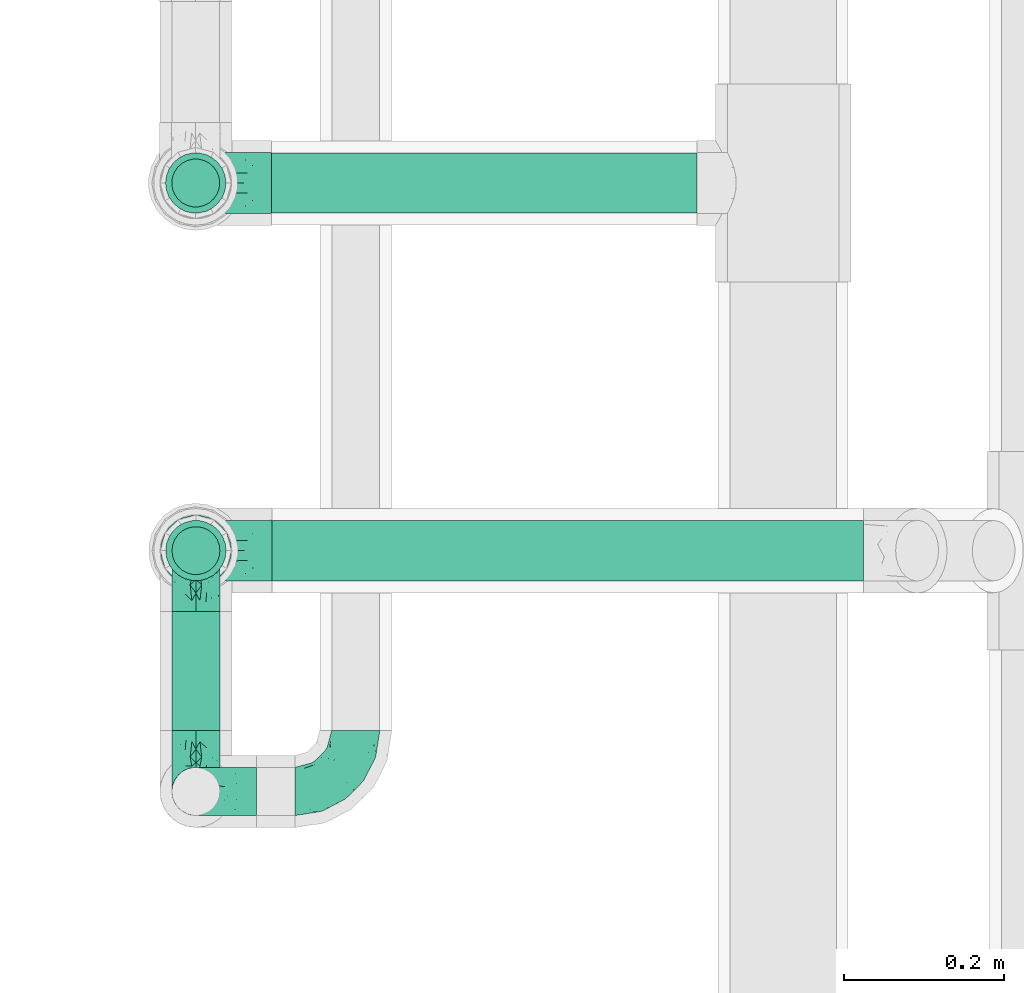
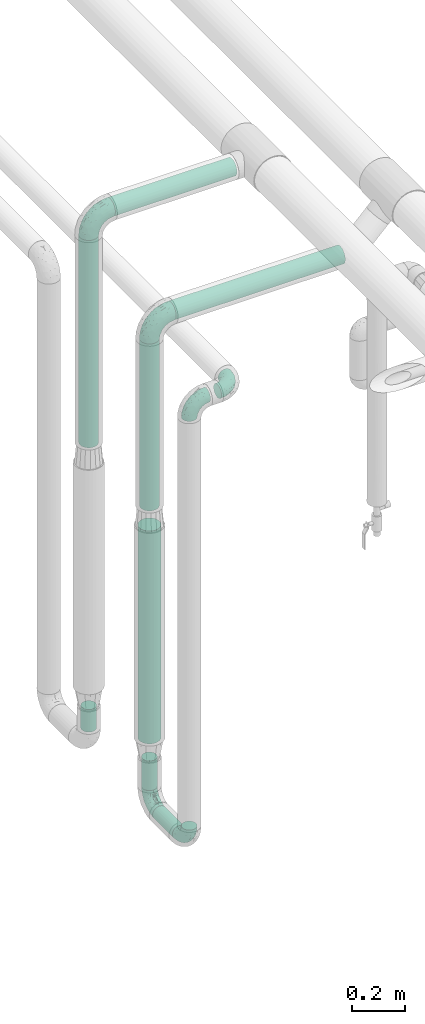
# One storey, part 553 of 824: 8 flow segments, 6 flow fittings.
"""IFC2X3 building model written with IfcOpenShell, lengths in millimetres."""

from ifc_helpers import new_model, entity, si_unit, converted_unit, derived_unit, direction, frame, origin, origin_2d_with_axis, place, context, subcontext, project, spatial, circle, extrude, faceted_brep, source, transform, mapped, material, type_object, type_shapes, element, save


model = new_model("IFC2X3")

# Units and contexts
model_context = context("Model", 3, precision=0.01, world=origin(), true_north=direction((6.12303176911189e-17, 1.0)))
body_context = subcontext(model_context, "Body", "Model", "MODEL_VIEW")
ifc_project = project(units=[si_unit("LENGTHUNIT", "METRE", prefix="MILLI"), si_unit("AREAUNIT", "SQUARE_METRE"), si_unit("VOLUMEUNIT", "CUBIC_METRE"), converted_unit("PLANEANGLEUNIT", "DEGREE", entity("IfcRatioMeasure", 0.0174532925199433), si_unit("PLANEANGLEUNIT", "RADIAN"), dimensions=[0, 0, 0, 0, 0, 0, 0]), si_unit("MASSUNIT", "GRAM", prefix="KILO"), derived_unit("MASSDENSITYUNIT", [(si_unit("MASSUNIT", "GRAM", prefix="KILO"), 1), (si_unit("LENGTHUNIT", "METRE"), -3)]), derived_unit("MOMENTOFINERTIAUNIT", [(si_unit("LENGTHUNIT", "METRE"), 4)]), si_unit("TIMEUNIT", "SECOND"), si_unit("FREQUENCYUNIT", "HERTZ"), si_unit("THERMODYNAMICTEMPERATUREUNIT", "DEGREE_CELSIUS"), derived_unit("THERMALTRANSMITTANCEUNIT", [(si_unit("MASSUNIT", "GRAM", prefix="KILO"), 1), (si_unit("THERMODYNAMICTEMPERATUREUNIT", "KELVIN"), -1), (si_unit("TIMEUNIT", "SECOND"), -3)]), derived_unit("VOLUMETRICFLOWRATEUNIT", [(si_unit("LENGTHUNIT", "METRE"), 3), (si_unit("TIMEUNIT", "SECOND"), -1)]), derived_unit("MASSFLOWRATEUNIT", [(si_unit("MASSUNIT", "GRAM", prefix="KILO"), 1), (si_unit("TIMEUNIT", "SECOND"), -1)]), derived_unit("ROTATIONALFREQUENCYUNIT", [(si_unit("TIMEUNIT", "SECOND"), -1)]), si_unit("ELECTRICCURRENTUNIT", "AMPERE"), si_unit("ELECTRICVOLTAGEUNIT", "VOLT"), si_unit("POWERUNIT", "WATT"), si_unit("FORCEUNIT", "NEWTON", prefix="KILO"), si_unit("ILLUMINANCEUNIT", "LUX"), si_unit("LUMINOUSFLUXUNIT", "LUMEN"), si_unit("LUMINOUSINTENSITYUNIT", "CANDELA"), derived_unit("USERDEFINED", [(si_unit("MASSUNIT", "GRAM", prefix="KILO"), -1), (si_unit("LENGTHUNIT", "METRE"), -2), (si_unit("TIMEUNIT", "SECOND"), 3), (si_unit("LUMINOUSFLUXUNIT", "LUMEN"), 1)]), derived_unit("LINEARVELOCITYUNIT", [(si_unit("LENGTHUNIT", "METRE"), 1), (si_unit("TIMEUNIT", "SECOND"), -1)]), si_unit("PRESSUREUNIT", "PASCAL"), derived_unit("USERDEFINED", [(si_unit("LENGTHUNIT", "METRE"), -2), (si_unit("MASSUNIT", "GRAM", prefix="KILO"), 1), (si_unit("TIMEUNIT", "SECOND"), -2)]), derived_unit("LINEARFORCEUNIT", [(si_unit("MASSUNIT", "GRAM", prefix="KILO"), 1), (si_unit("LENGTHUNIT", "METRE"), 1), (si_unit("TIMEUNIT", "SECOND"), -2), (si_unit("LENGTHUNIT", "METRE"), -1)]), derived_unit("PLANARFORCEUNIT", [(si_unit("MASSUNIT", "GRAM", prefix="KILO"), 1), (si_unit("LENGTHUNIT", "METRE"), 1), (si_unit("TIMEUNIT", "SECOND"), -2), (si_unit("LENGTHUNIT", "METRE"), -2)])], contexts=[model_context])

# Site, building, storey
site_placement = place(None, origin())
site = spatial("IfcSite", under=ifc_project, at=site_placement, CompositionType="ELEMENT")
building_placement = place(site_placement, origin())
building = spatial("IfcBuilding", under=site, at=building_placement, CompositionType="ELEMENT")
storey_placement = place(building_placement, frame((0.0, 0.0, 28200.0)))
storey = spatial("IfcBuildingStorey", under=building, at=storey_placement, CompositionType="ELEMENT", Elevation=28200.0)

# Flow segments
pipe_segment_type = type_object("IfcPipeSegmentType", PredefinedType="NOTDEFINED")
flow_segment_1_placement = place(storey_placement, frame((21195.29, 10760.3, 2560.65)))
element("IfcFlowSegment", 1, at=flow_segment_1_placement, inside=storey, type_object=pipe_segment_type, context=body_context, shape_type="SweptSolid", body=[
    extrude(circle(Radius=37.75, at=origin_2d_with_axis()), frame((0.0, 39.35, 39.35), z_axis=(1.0, 0.0, 0.0), x_axis=(0.0, -1.0, 0.0)), (0.0, 0.0, 1.0), 740.186732047182),
])
flow_segment_2_placement = place(storey_placement, frame((21195.05, 11220.3, 2760.65)))
element("IfcFlowSegment", 2, at=flow_segment_2_placement, inside=storey, type_object=pipe_segment_type, context=body_context, shape_type="SweptSolid", body=[
    extrude(circle(Radius=37.75, at=origin_2d_with_axis()), frame((0.0, 39.35, 39.35), z_axis=(1.0, 0.0, 0.0), x_axis=(0.0, 1.0, 0.0)), (0.0, 0.0, 1.0), 532.054122561678),
])
flow_segment_3_placement = place(storey_placement, frame((21060.71, 11220.3, 1745.76)))
element("IfcFlowSegment", 3, at=flow_segment_3_placement, inside=storey, type_object=pipe_segment_type, context=body_context, shape_type="SweptSolid", body=[
    extrude(circle(Radius=37.75, at=origin_2d_with_axis()), frame((39.35, 39.35, 0.0)), (0.0, 0.0, 1.0), 959.235677321025),
])
flow_segment_4_placement = place(storey_placement, frame((21060.95, 10760.3, 1732.85)))
element("IfcFlowSegment", 4, at=flow_segment_4_placement, inside=storey, type_object=pipe_segment_type, context=body_context, shape_type="SweptSolid", body=[
    extrude(circle(Radius=37.75, at=origin_2d_with_axis()), frame((39.35, 39.35, 0.0)), (0.0, 0.0, 1.0), 772.147698373087),
])
flow_segment_5_placement = place(storey_placement, frame((21068.46, 11228.05, 426.01)))
element("IfcFlowSegment", 5, at=flow_segment_5_placement, inside=storey, type_object=pipe_segment_type, context=body_context, shape_type="SweptSolid", body=[
    extrude(circle(Radius=30.0, at=origin_2d_with_axis()), frame((31.6, 31.6, 0.0), z_axis=(0.0, 0.0, 1.0), x_axis=(-1.0, 0.0, 0.0)), (0.0, 0.0, 1.0), 103.990099363139),
])
flow_segment_6_placement = place(storey_placement, frame((21068.7, 10574.33, 326.66)))
element("IfcFlowSegment", 6, at=flow_segment_6_placement, inside=storey, type_object=pipe_segment_type, context=body_context, shape_type="SweptSolid", body=[
    extrude(circle(Radius=30.0, at=origin_2d_with_axis()), frame((31.6, 0.0, 31.6), z_axis=(0.0, 1.0, 0.0), x_axis=(1.0, 0.0, 0.0)), (0.0, 0.0, 1.0), 149.321853330202),
])
flow_segment_7_placement = place(storey_placement, frame((21068.7, 10768.05, 434.26)))
element("IfcFlowSegment", 7, at=flow_segment_7_placement, inside=storey, type_object=pipe_segment_type, context=body_context, shape_type="SweptSolid", body=[
    extrude(circle(Radius=30.0, at=origin_2d_with_axis()), frame((31.6, 31.6, 0.0), z_axis=(0.0, 0.0, 1.0), x_axis=(-1.0, 0.0, 0.0)), (0.0, 0.0, 1.0), 137.000000000008),
])
flow_segment_8_placement = place(storey_placement, frame((21054.45, 10753.8, 660.26)))
element("IfcFlowSegment", 8, at=flow_segment_8_placement, inside=storey, type_object=pipe_segment_type, context=body_context, shape_type="SweptSolid", body=[
    extrude(circle(Radius=44.25, at=origin_2d_with_axis()), frame((45.85, 45.85, 0.0), z_axis=(0.0, 0.0, 1.0), x_axis=(-1.0, 0.0, 0.0)), (0.0, 0.0, 1.0), 983.596806403876),
])

# Flow fittings
ifc_material = material()
pipe_fitting_type_1 = type_object("IfcPipeFittingType", PredefinedType="NOTDEFINED", material=ifc_material)
shared_shape_1 = source(origin(), body_context, "Body", "Brep", [
    faceted_brep([(-76.0, 15.07, -26.11), (-76.0, 7.8, -29.12), (-76.0, 0.0, -30.15), (-76.0, -7.8, -29.12), (-76.0, -15.08, -26.11), (-76.0, -21.32, -21.32), (-76.0, -26.11, -15.08), (-76.0, -29.12, -7.8), (-76.0, -30.15, 0.0), (-76.0, -29.12, 7.8), (-76.0, -26.11, 15.07), (-76.0, -21.32, 21.32), (-76.0, -15.08, 26.11), (-76.0, -7.8, 29.12), (-76.0, 0.0, 30.15), (-76.0, 7.8, 29.12), (-76.0, 15.07, 26.11), (-76.0, 21.32, 21.32), (-76.0, 26.11, 15.07), (-76.0, 29.12, 7.8), (-76.0, 30.15, 0.0), (-76.0, 29.12, -7.8), (-76.0, 26.11, -15.08), (-76.0, 21.32, -21.32), (0.0, 76.0, -30.15), (-7.8, 76.0, -29.12), (-15.07, 76.0, -26.11), (-21.32, 76.0, -21.32), (-26.11, 76.0, -15.08), (-29.12, 76.0, -7.8), (-30.15, 76.0, 0.0), (-29.12, 76.0, 7.8), (-26.11, 76.0, 15.07), (-21.32, 76.0, 21.32), (-15.07, 76.0, 26.11), (-7.8, 76.0, 29.12), (0.0, 76.0, 30.15), (7.8, 76.0, 29.12), (15.08, 76.0, 26.11), (21.32, 76.0, 21.32), (26.11, 76.0, 15.07), (29.12, 76.0, 7.8), (30.15, 76.0, 0.0), (29.12, 76.0, -7.8), (26.11, 76.0, -15.08), (21.32, 76.0, -21.32), (15.08, 76.0, -26.11), (7.8, 76.0, -29.12), (10.79, 31.43, 21.07), (4.32, 31.7, 25.72), (1.65, 15.19, 19.92), (-61.17, -27.8, 0.0), (-51.1, -25.49, 9.84), (-56.14, -10.61, 27.27), (-31.7, -4.32, 25.72), (-39.75, 1.72, 29.41), (-43.2, -24.95, 0.0), (-1.86, 1.86, 0.0), (4.49, 7.65, 5.78), (-7.82, -4.61, 5.83), (-56.21, -22.79, 17.21), (-58.98, -3.38, 29.7), (-53.96, 5.6, 30.07), (-10.86, 10.86, 25.48), (-17.2, -2.6, 20.44), (-49.15, -16.01, 22.7), (-22.18, -14.24, 7.99), (-28.4, -17.42, 0.0), (-13.61, -9.88, 0.0), (-39.0, 23.48, 27.76), (-58.76, 12.54, 28.36), (-41.61, 15.41, 29.48), (16.01, 49.15, 22.7), (-58.55, 25.93, 19.53), (-51.53, 33.5, 13.51), (-64.92, 28.76, 12.4), (-7.48, 23.14, 28.25), (-1.72, 39.75, 29.41), (-12.04, 27.88, 29.88), (-63.91, 18.81, 24.52), (-11.63, 65.16, 28.18), (-4.97, 57.02, 30.05), (9.88, 13.61, 0.0), (-62.5, 31.74, 5.02), (-45.17, 30.98, 21.2), (-21.78, 9.76, 28.58), (10.61, 56.14, 27.27), (-32.09, 54.42, 13.26), (22.79, 56.21, 17.21), (15.38, 31.17, 15.63), (25.49, 51.1, 9.84), (21.84, 36.35, 5.92), (24.95, 43.2, 0.0), (3.38, 58.98, 29.7), (-31.17, -15.38, 15.63), (-39.39, 41.78, 15.45), (-34.56, 41.13, 20.79), (-39.81, -23.25, 5.49), (27.8, 61.17, 0.0), (-31.74, 62.5, 5.02), (-53.07, 36.29, 0.0), (-42.95, 42.95, 7.29), (-36.29, 53.07, 0.0), (-19.83, 58.51, 24.79), (-25.48, 60.2, 19.41), (-14.53, 50.96, 28.57), (-13.31, 37.09, 30.07), (-26.16, 40.06, 26.4), (-32.43, -10.35, 21.9), (17.42, 28.4, 0.0), (14.24, 22.18, 7.99), (-38.67, 9.72, 30.15), (-24.66, 17.36, 30.09), (-37.08, 31.49, 24.99), (-49.27, 22.83, 25.24), (-20.8, 38.81, 28.63), (-27.58, 27.58, 29.2), (-36.07, -20.23, 10.71), (-15.19, -6.16, 14.9), (6.6, 15.4, 14.49), (-2.51, 2.51, 11.35), (-65.16, 11.63, -28.18), (-49.15, -16.01, -22.7), (-57.02, 4.97, -30.05), (-25.93, 58.55, -19.53), (-33.5, 51.53, -13.51), (-28.76, 64.92, -12.4), (-60.2, 25.48, -19.41), (-58.51, 19.83, -24.79), (4.61, 7.82, -5.83), (-7.65, -4.49, -5.78), (-2.51, 2.51, -11.35), (-62.5, 31.74, -5.02), (-50.96, 14.53, -28.57), (-37.09, 13.31, -30.07), (-42.95, 42.95, -7.29), (25.49, 51.1, -9.84), (22.79, 56.21, -17.21), (-40.06, 26.16, -26.4), (3.38, 58.98, -29.7), (-5.6, 53.96, -30.07), (-27.88, 12.04, -29.88), (-9.76, 21.78, -28.58), (-23.14, 7.48, -28.25), (-51.1, -25.49, -9.84), (15.38, 31.17, -15.63), (16.01, 49.15, -22.7), (-23.48, 39.0, -27.76), (-12.54, 58.76, -28.36), (-15.41, 41.61, -29.48), (-56.21, -22.79, -17.21), (-9.72, 38.67, -30.15), (-17.36, 24.66, -30.09), (-22.18, -14.24, -7.99), (-41.13, 34.56, -20.79), (-31.74, 62.5, -5.02), (-58.98, -3.38, -29.7), (-31.17, -15.38, -15.63), (-56.14, -10.61, -27.27), (14.24, 22.18, -7.99), (23.25, 39.81, -5.49), (-31.49, 37.08, -24.99), (-15.19, -6.16, -14.9), (1.65, 15.19, -19.92), (-18.81, 63.91, -24.52), (-32.59, -11.62, -20.84), (-31.7, -4.32, -25.72), (-17.2, -2.6, -20.44), (-39.75, 1.72, -29.41), (-54.42, 32.09, -13.26), (-30.98, 45.17, -21.2), (10.61, 56.14, -27.27), (10.23, 31.31, -21.52), (4.32, 31.7, -25.72), (-41.78, 39.39, -15.45), (-1.72, 39.75, -29.41), (-36.35, -21.84, -5.92), (-22.83, 49.27, -25.24), (-38.81, 20.8, -28.63), (-27.58, 27.58, -29.2), (-10.86, 10.86, -25.48), (20.23, 36.07, -10.71), (6.6, 15.4, -14.49)], [[[0, 1, 2, 3, 4, 5, 6, 7, 8, 9, 10, 11, 12, 13, 14, 15, 16, 17, 18, 19, 20, 21, 22, 23]], [[24, 25, 26, 27, 28, 29, 30, 31, 32, 33, 34, 35, 36, 37, 38, 39, 40, 41, 42, 43, 44, 45, 46, 47]], [[48, 49, 50]], [[51, 52, 9]], [[53, 54, 55]], [[9, 52, 10]], [[56, 52, 51]], [[57, 58, 59]], [[11, 10, 60]], [[14, 61, 62]], [[63, 54, 64]], [[65, 12, 11]], [[65, 53, 12]], [[66, 67, 68]], [[69, 70, 71]], [[72, 39, 38]], [[73, 74, 75]], [[15, 70, 16]], [[76, 77, 78]], [[16, 79, 17]], [[13, 61, 14]], [[35, 80, 81]], [[14, 62, 15]], [[17, 73, 18]], [[57, 82, 58]], [[20, 19, 83]], [[75, 19, 18]], [[70, 15, 62]], [[73, 84, 74]], [[78, 85, 76]], [[38, 86, 72]], [[32, 31, 87]], [[88, 89, 90]], [[91, 92, 90]], [[72, 86, 49]], [[36, 93, 37]], [[75, 83, 19]], [[36, 35, 81]], [[60, 94, 65]], [[40, 90, 41]], [[95, 96, 87]], [[88, 90, 40]], [[66, 97, 67]], [[90, 98, 41]], [[40, 39, 88]], [[99, 31, 30]], [[20, 83, 100]], [[101, 102, 100]], [[52, 60, 10]], [[102, 99, 30]], [[96, 103, 104]], [[83, 101, 100]], [[12, 53, 13]], [[104, 103, 33]], [[105, 106, 81]], [[107, 105, 103]], [[64, 54, 108]], [[80, 103, 105]], [[80, 35, 34]], [[34, 33, 103]], [[86, 38, 37]], [[109, 110, 82]], [[71, 111, 112]], [[69, 107, 113]], [[79, 73, 17]], [[114, 113, 84]], [[33, 32, 104]], [[115, 107, 116]], [[105, 115, 106]], [[93, 81, 77]], [[54, 53, 65]], [[61, 53, 55]], [[108, 94, 64]], [[54, 63, 85]], [[93, 86, 37]], [[77, 76, 49]], [[77, 49, 86]], [[49, 63, 50]], [[60, 52, 117]], [[65, 11, 60]], [[39, 72, 88]], [[89, 88, 72]], [[71, 70, 62]], [[79, 70, 114]], [[103, 96, 107]], [[69, 113, 114]], [[112, 106, 116]], [[77, 81, 106]], [[112, 116, 71]], [[112, 55, 85]], [[64, 50, 63]], [[57, 59, 68]], [[32, 87, 104]], [[96, 104, 87]], [[94, 118, 64]], [[50, 119, 89]], [[50, 64, 118]], [[50, 89, 48]], [[81, 93, 36]], [[86, 93, 77]], [[53, 61, 13]], [[62, 61, 55]], [[71, 62, 111]], [[69, 71, 116]], [[95, 101, 74]], [[99, 101, 87]], [[118, 66, 59]], [[117, 97, 66]], [[117, 66, 94]], [[91, 89, 110]], [[91, 110, 109]], [[110, 89, 119]], [[9, 8, 51]], [[98, 90, 92]], [[98, 42, 41]], [[101, 83, 74]], [[101, 99, 102]], [[87, 31, 99]], [[62, 55, 111]], [[55, 112, 111]], [[107, 69, 116]], [[70, 69, 114]], [[107, 96, 113]], [[84, 113, 96]], [[84, 96, 95]], [[114, 84, 73]], [[70, 79, 16]], [[73, 79, 114]], [[54, 85, 55]], [[76, 85, 63]], [[49, 76, 63]], [[77, 106, 78]], [[106, 112, 78]], [[85, 78, 112]], [[73, 75, 18]], [[83, 75, 74]], [[103, 80, 34]], [[81, 80, 105]], [[101, 95, 87]], [[84, 95, 74]], [[106, 115, 116]], [[105, 107, 115]], [[120, 59, 58]], [[82, 110, 58]], [[119, 58, 110]], [[118, 59, 120]], [[66, 68, 59]], [[54, 65, 108]], [[94, 108, 65]], [[66, 118, 94]], [[50, 118, 120]], [[50, 120, 119]], [[119, 120, 58]], [[89, 72, 48]], [[49, 48, 72]], [[60, 117, 94]], [[117, 52, 97]], [[52, 56, 97]], [[67, 97, 56]], [[92, 91, 109]], [[89, 91, 90]], [[121, 1, 0]], [[122, 5, 4]], [[2, 1, 123]], [[124, 125, 126]], [[127, 128, 23]], [[129, 130, 131]], [[100, 132, 20]], [[133, 134, 123]], [[135, 100, 102]], [[136, 137, 44]], [[133, 128, 138]], [[24, 139, 140]], [[141, 142, 143]], [[121, 128, 133]], [[6, 144, 7]], [[137, 145, 146]], [[144, 51, 7]], [[147, 148, 149]], [[144, 6, 150]], [[149, 151, 152]], [[153, 68, 67]], [[154, 128, 127]], [[30, 155, 102]], [[43, 42, 98]], [[156, 3, 2]], [[157, 144, 150]], [[158, 4, 3]], [[24, 140, 25]], [[155, 135, 102]], [[159, 160, 109]], [[30, 29, 155]], [[147, 138, 161]], [[27, 124, 28]], [[57, 129, 82]], [[162, 163, 131]], [[27, 26, 164]], [[148, 26, 25]], [[165, 166, 167]], [[24, 47, 139]], [[143, 168, 141]], [[22, 21, 169]], [[125, 124, 170]], [[148, 25, 140]], [[46, 146, 171]], [[158, 122, 4]], [[0, 23, 128]], [[1, 121, 123]], [[109, 82, 159]], [[45, 44, 137]], [[146, 46, 45]], [[136, 43, 98]], [[132, 21, 20]], [[136, 98, 92]], [[172, 173, 146]], [[46, 171, 47]], [[43, 136, 44]], [[174, 154, 169]], [[171, 173, 175]], [[6, 5, 150]], [[126, 29, 28]], [[176, 56, 144]], [[122, 158, 166]], [[164, 124, 27]], [[177, 161, 170]], [[23, 22, 127]], [[178, 138, 179]], [[133, 178, 134]], [[156, 123, 168]], [[156, 158, 3]], [[168, 143, 166]], [[168, 166, 158]], [[166, 180, 167]], [[173, 171, 146]], [[139, 171, 175]], [[172, 145, 163]], [[173, 180, 142]], [[5, 122, 150]], [[157, 150, 122]], [[137, 136, 181]], [[146, 45, 137]], [[149, 148, 140]], [[164, 148, 177]], [[128, 154, 138]], [[147, 161, 177]], [[152, 134, 179]], [[168, 123, 134]], [[152, 179, 149]], [[152, 175, 142]], [[57, 130, 129]], [[157, 165, 167]], [[22, 169, 127]], [[154, 127, 169]], [[163, 167, 180]], [[162, 157, 167]], [[173, 163, 180]], [[182, 163, 145]], [[123, 156, 2]], [[158, 156, 168]], [[171, 139, 47]], [[140, 139, 175]], [[149, 140, 151]], [[147, 149, 179]], [[174, 135, 125]], [[132, 135, 169]], [[176, 157, 153]], [[176, 153, 67]], [[153, 157, 162]], [[182, 159, 129]], [[181, 160, 159]], [[181, 159, 145]], [[51, 144, 56]], [[51, 8, 7]], [[135, 132, 100]], [[169, 21, 132]], [[126, 155, 29]], [[135, 155, 125]], [[140, 175, 151]], [[175, 152, 151]], [[138, 147, 179]], [[148, 147, 177]], [[138, 154, 161]], [[170, 161, 154]], [[170, 154, 174]], [[177, 170, 124]], [[148, 164, 26]], [[124, 164, 177]], [[173, 142, 175]], [[143, 142, 180]], [[166, 143, 180]], [[168, 134, 141]], [[134, 152, 141]], [[142, 141, 152]], [[124, 126, 28]], [[155, 126, 125]], [[128, 121, 0]], [[123, 121, 133]], [[135, 174, 169]], [[170, 174, 125]], [[134, 178, 179]], [[133, 138, 178]], [[130, 153, 162]], [[68, 153, 130]], [[57, 68, 130]], [[182, 129, 131]], [[159, 82, 129]], [[157, 122, 165]], [[166, 165, 122]], [[163, 162, 167]], [[162, 131, 130]], [[145, 172, 146]], [[163, 173, 172]], [[159, 182, 145]], [[131, 163, 182]], [[56, 176, 67]], [[157, 176, 144]], [[137, 181, 145]], [[181, 136, 160]], [[136, 92, 160]], [[109, 160, 92]]]),
])
type_shapes(pipe_fitting_type_1, [shared_shape_1])
flow_fitting_placement = place(storey_placement, frame((21300.24, 10498.33, 2400.0)))
element("IfcFlowFitting", 9, at=flow_fitting_placement, inside=storey, type_object=pipe_fitting_type_1, material=ifc_material, context=body_context, shape_type="MappedRepresentation", body=[
    mapped(shared_shape_1, transform((0.0, 0.0, 0.0), scale=1.0)),
])
for number, where, z_axis, x_axis in (
    (10, (21100.29, 10498.33, 2400.0), (0.0, -1.0, 0.0), (-1.0, 0.0, 0.0)),
    (11, (21100.29, 10498.33, 358.26), (1.0, 0.0, 0.0), (0.0, 0.0, -1.0)),
    (12, (21100.29, 10799.65, 358.26), (1.0, 0.0, 0.0), (0.0, 1.0, 0.0)),
):
    element("IfcFlowFitting", number, at=place(storey_placement, frame(where, z_axis=z_axis, x_axis=x_axis)), inside=storey, type_object=pipe_fitting_type_1, material=ifc_material, context=body_context, shape_type="MappedRepresentation", body=[
        mapped(shared_shape_1, transform((0.0, 0.0, 0.0), scale=1.0)),
    ])
pipe_fitting_type_2 = type_object("IfcPipeFittingType", PredefinedType="NOTDEFINED", material=ifc_material)
shared_shape_2 = source(origin(), body_context, "Body", "Brep", [
    faceted_brep([(-95.0, 19.02, -32.95), (-95.0, 9.85, -36.75), (-95.0, 0.0, -38.05), (-95.0, -9.85, -36.75), (-95.0, -19.03, -32.95), (-95.0, -26.91, -26.91), (-95.0, -32.95, -19.03), (-95.0, -36.75, -9.85), (-95.0, -38.05, 0.0), (-95.0, -36.75, 9.85), (-95.0, -32.95, 19.02), (-95.0, -26.91, 26.91), (-95.0, -19.03, 32.95), (-95.0, -9.85, 36.75), (-95.0, 0.0, 38.05), (-95.0, 9.85, 36.75), (-95.0, 19.02, 32.95), (-95.0, 26.91, 26.91), (-95.0, 32.95, 19.02), (-95.0, 36.75, 9.85), (-95.0, 38.05, 0.0), (-95.0, 36.75, -9.85), (-95.0, 32.95, -19.03), (-95.0, 26.91, -26.91), (0.0, 95.0, -38.05), (-9.85, 95.0, -36.75), (-19.02, 95.0, -32.95), (-26.91, 95.0, -26.91), (-32.95, 95.0, -19.03), (-36.75, 95.0, -9.85), (-38.05, 95.0, 0.0), (-36.75, 95.0, 9.85), (-32.95, 95.0, 19.02), (-26.91, 95.0, 26.91), (-19.02, 95.0, 32.95), (-9.85, 95.0, 36.75), (0.0, 95.0, 38.05), (9.85, 95.0, 36.75), (19.03, 95.0, 32.95), (26.91, 95.0, 26.91), (32.95, 95.0, 19.02), (36.75, 95.0, 9.85), (38.05, 95.0, 0.0), (36.75, 95.0, -9.85), (32.95, 95.0, -19.03), (26.91, 95.0, -26.91), (19.03, 95.0, -32.95), (9.85, 95.0, -36.75), (-7.99, -4.96, 6.3), (-0.92, 0.92, 0.0), (4.62, 8.1, 8.01), (-76.19, -35.57, 0.0), (-64.32, -32.32, 12.43), (20.51, 62.45, 28.68), (-60.56, -33.52, 0.0), (-70.4, -13.47, 34.42), (-39.61, -5.88, 32.32), (-49.6, 2.07, 37.1), (-70.34, -28.81, 21.71), (14.64, 40.81, 26.5), (5.88, 39.61, 32.32), (3.59, 20.77, 25.31), (-40.45, 68.06, 16.75), (-62.45, -20.51, 28.68), (-44.52, -26.87, 0.0), (-28.47, -20.22, 0.0), (-26.43, -17.83, 8.75), (-76.1, 39.63, 10.76), (-72.74, 37.58, 18.19), (-60.35, 46.18, 14.61), (-13.4, 13.4, 32.12), (-20.77, -3.59, 25.31), (-14.66, 81.47, 35.56), (-6.22, 71.26, 37.92), (-57.5, 42.48, 22.79), (-15.0, 34.74, 37.7), (-27.1, 12.08, 36.05), (-9.2, 28.81, 35.63), (-79.98, 23.7, 30.95), (-73.68, -4.3, 37.48), (-30.74, 21.67, 37.97), (-62.36, 47.59, 6.79), (-72.71, 32.83, 24.69), (-67.42, 7.02, 37.95), (-32.13, 75.27, 24.51), (-43.46, 51.47, 26.26), (-24.98, 73.15, 31.29), (20.59, 41.28, 19.85), (7.79, 16.09, 15.86), (-73.21, 42.39, 0.0), (-54.73, 54.73, 0.0), (-73.44, 15.79, 35.79), (-5.94, 4.32, 20.43), (28.81, 70.34, 21.71), (32.32, 64.32, 12.43), (-53.59, 26.2, 35.09), (-52.02, 19.31, 37.21), (21.38, 33.53, 10.34), (26.87, 44.52, 0.0), (-48.28, 12.14, 38.05), (4.3, 73.68, 37.48), (-44.08, -25.52, 12.79), (-41.28, -20.59, 19.85), (35.57, 76.19, 0.0), (-47.26, 54.3, 20.18), (-47.4, 61.99, 8.58), (-42.39, 73.21, 0.0), (-39.67, 78.86, 7.21), (-45.69, 36.84, 33.11), (-32.83, 50.13, 33.35), (13.47, 70.4, 34.42), (-18.25, 63.73, 36.07), (-40.63, -13.75, 27.22), (-16.63, 46.37, 37.95), (-53.47, 38.79, 28.59), (-26.07, 48.54, 36.15), (-34.51, 34.51, 36.86), (-2.07, 49.6, 37.1), (-22.79, -10.49, 19.23), (-61.73, 28.67, 31.87), (9.65, 14.7, 0.0), (20.22, 28.47, 0.0), (33.52, 60.56, 0.0), (-11.42, -5.44, 13.25), (-14.7, -9.65, 0.0), (-81.47, 14.66, -35.56), (-62.45, -20.51, -28.68), (-71.26, 6.22, -37.92), (-75.27, 32.13, -24.51), (-73.15, 24.98, -31.29), (13.47, 70.4, -34.42), (5.88, 39.61, -32.32), (-2.07, 49.6, -37.1), (-78.86, 39.67, -7.21), (-70.4, -13.47, -34.42), (-39.61, -5.88, -32.32), (-61.99, 47.4, -8.58), (32.32, 64.32, -12.43), (28.81, 70.34, -21.71), (-63.73, 18.25, -36.07), (-50.13, 32.83, -33.35), (4.3, 73.68, -37.48), (-7.02, 67.42, -37.95), (-39.63, 76.1, -10.76), (-46.18, 60.35, -14.61), (-47.59, 62.36, -6.79), (-64.32, -32.32, -12.43), (-26.2, 53.59, -35.09), (-15.79, 73.44, -35.79), (-19.31, 52.02, -37.21), (-37.58, 72.74, -18.19), (-70.34, -28.81, -21.71), (-42.48, 57.5, -22.79), (-38.79, 53.47, -28.59), (-51.47, 43.46, -26.26), (-32.83, 72.71, -24.69), (-46.37, 16.63, -37.95), (-73.68, -4.3, -37.48), (-41.28, -20.59, -19.85), (-44.08, -25.52, -12.79), (13.75, 40.63, -27.22), (20.51, 62.45, -28.68), (-68.06, 40.45, -16.75), (-54.3, 47.26, -20.18), (-12.14, 48.28, -38.05), (-21.67, 30.74, -37.97), (-36.84, 45.69, -33.11), (-11.42, -5.44, -13.25), (7.79, 16.09, -15.86), (4.62, 8.1, -8.01), (-23.7, 79.98, -30.95), (-26.43, -17.83, -8.75), (-7.99, -4.96, -6.3), (-40.81, -14.64, -26.5), (-20.77, -3.59, -25.31), (-34.74, 15.0, -37.7), (-12.08, 27.1, -36.05), (-28.81, 9.2, -35.63), (-22.79, -10.49, -19.23), (21.38, 33.53, -10.34), (20.59, 41.28, -19.85), (-48.54, 26.07, -36.15), (-49.6, 2.07, -37.1), (-13.4, 13.4, -32.12), (3.59, 20.77, -25.31), (-28.67, 61.73, -31.87), (-34.51, 34.51, -36.86), (-5.94, 4.32, -20.43)], [[[0, 1, 2, 3, 4, 5, 6, 7, 8, 9, 10, 11, 12, 13, 14, 15, 16, 17, 18, 19, 20, 21, 22, 23]], [[24, 25, 26, 27, 28, 29, 30, 31, 32, 33, 34, 35, 36, 37, 38, 39, 40, 41, 42, 43, 44, 45, 46, 47]], [[48, 49, 50]], [[51, 52, 9]], [[53, 39, 38]], [[9, 52, 10]], [[54, 52, 51]], [[55, 56, 57]], [[11, 10, 58]], [[59, 60, 61]], [[32, 31, 62]], [[63, 12, 11]], [[63, 55, 12]], [[64, 65, 66]], [[67, 68, 69]], [[70, 56, 71]], [[35, 72, 73]], [[69, 68, 74]], [[75, 76, 77]], [[16, 78, 17]], [[13, 79, 14]], [[76, 75, 80]], [[67, 69, 81]], [[18, 17, 82]], [[14, 79, 83]], [[20, 19, 67]], [[84, 85, 86]], [[87, 61, 88]], [[89, 81, 90]], [[18, 82, 68]], [[15, 91, 16]], [[14, 83, 15]], [[71, 92, 61]], [[17, 78, 82]], [[93, 87, 94]], [[95, 91, 96]], [[97, 98, 94]], [[86, 72, 34]], [[96, 99, 80]], [[37, 36, 100]], [[40, 39, 93]], [[40, 94, 41]], [[64, 66, 101]], [[93, 94, 40]], [[58, 102, 63]], [[94, 103, 41]], [[94, 87, 97]], [[104, 69, 74]], [[34, 33, 86]], [[105, 69, 104]], [[52, 58, 10]], [[106, 107, 30]], [[108, 109, 85]], [[105, 106, 90]], [[53, 110, 60]], [[86, 111, 72]], [[86, 109, 111]], [[33, 84, 86]], [[12, 55, 13]], [[112, 56, 63]], [[110, 38, 37]], [[34, 72, 35]], [[36, 35, 73]], [[111, 113, 73]], [[105, 107, 106]], [[110, 53, 38]], [[74, 114, 85]], [[91, 15, 83]], [[105, 90, 81]], [[107, 62, 31]], [[33, 32, 84]], [[115, 109, 116]], [[111, 115, 113]], [[100, 73, 117]], [[56, 55, 63]], [[79, 55, 57]], [[102, 118, 112]], [[56, 70, 76]], [[100, 110, 37]], [[117, 77, 60]], [[117, 60, 110]], [[60, 70, 61]], [[58, 52, 101]], [[63, 11, 58]], [[39, 53, 93]], [[87, 93, 53]], [[96, 91, 83]], [[78, 91, 119]], [[32, 62, 84]], [[84, 62, 104]], [[86, 85, 109]], [[85, 114, 108]], [[80, 113, 116]], [[117, 73, 113]], [[80, 116, 96]], [[80, 57, 76]], [[71, 112, 118]], [[61, 87, 59]], [[62, 107, 105]], [[97, 120, 121]], [[70, 71, 61]], [[71, 118, 92]], [[73, 100, 36]], [[110, 100, 117]], [[55, 79, 13]], [[83, 79, 57]], [[96, 83, 99]], [[116, 108, 95]], [[50, 97, 88]], [[97, 87, 88]], [[50, 49, 120]], [[122, 94, 98]], [[89, 20, 67]], [[105, 81, 69]], [[89, 67, 81]], [[68, 19, 18]], [[68, 67, 19]], [[74, 68, 82]], [[114, 82, 119]], [[74, 85, 104]], [[82, 114, 74]], [[114, 119, 108]], [[95, 108, 119]], [[116, 109, 108]], [[123, 48, 50]], [[97, 50, 120]], [[123, 50, 88]], [[91, 95, 119]], [[116, 95, 96]], [[84, 104, 85]], [[104, 62, 105]], [[83, 57, 99]], [[57, 80, 99]], [[66, 48, 123]], [[66, 124, 48]], [[118, 66, 123]], [[124, 66, 65]], [[66, 118, 101]], [[54, 64, 52]], [[124, 49, 48]], [[30, 107, 31]], [[91, 78, 16]], [[82, 78, 119]], [[56, 76, 57]], [[77, 76, 70]], [[60, 77, 70]], [[77, 117, 75]], [[117, 113, 75]], [[113, 80, 75]], [[9, 8, 51]], [[103, 94, 122]], [[103, 42, 41]], [[73, 72, 111]], [[113, 115, 116]], [[111, 109, 115]], [[102, 112, 63]], [[71, 56, 112]], [[118, 102, 101]], [[92, 123, 88]], [[123, 92, 118]], [[61, 92, 88]], [[87, 53, 59]], [[60, 59, 53]], [[97, 121, 98]], [[58, 101, 102]], [[64, 101, 52]], [[125, 1, 0]], [[126, 5, 4]], [[2, 1, 127]], [[1, 125, 127]], [[128, 129, 23]], [[130, 131, 132]], [[89, 133, 20]], [[126, 134, 135]], [[136, 89, 90]], [[137, 138, 44]], [[139, 129, 140]], [[24, 141, 142]], [[143, 144, 145]], [[125, 129, 139]], [[6, 146, 7]], [[147, 148, 149]], [[146, 51, 7]], [[143, 150, 144]], [[146, 6, 151]], [[152, 153, 154]], [[126, 4, 134]], [[0, 23, 129]], [[28, 155, 150]], [[43, 42, 103]], [[54, 146, 64]], [[139, 156, 127]], [[157, 3, 2]], [[151, 158, 159]], [[160, 131, 161]], [[22, 21, 162]], [[136, 144, 163]], [[149, 164, 165]], [[24, 142, 25]], [[166, 140, 154]], [[154, 129, 128]], [[143, 30, 29]], [[167, 168, 169]], [[155, 28, 27]], [[26, 170, 27]], [[171, 167, 172]], [[26, 25, 148]], [[27, 170, 155]], [[173, 135, 174]], [[144, 150, 152]], [[175, 176, 177]], [[24, 47, 141]], [[45, 161, 46]], [[148, 25, 142]], [[176, 175, 165]], [[64, 159, 171]], [[138, 45, 44]], [[130, 46, 161]], [[137, 44, 43]], [[178, 159, 158]], [[137, 103, 122]], [[163, 144, 152]], [[136, 133, 89]], [[103, 137, 43]], [[6, 5, 151]], [[178, 158, 173]], [[134, 4, 3]], [[178, 173, 174]], [[137, 98, 179]], [[145, 90, 106]], [[138, 180, 161]], [[46, 130, 47]], [[136, 90, 145]], [[133, 162, 21]], [[23, 22, 128]], [[139, 140, 181]], [[139, 181, 156]], [[157, 127, 182]], [[157, 134, 3]], [[182, 177, 135]], [[182, 135, 134]], [[135, 183, 174]], [[131, 130, 161]], [[141, 130, 132]], [[160, 180, 184]], [[131, 183, 176]], [[5, 126, 151]], [[158, 151, 126]], [[180, 138, 137]], [[161, 45, 138]], [[149, 148, 142]], [[170, 148, 185]], [[22, 162, 128]], [[128, 162, 163]], [[129, 154, 140]], [[154, 153, 166]], [[165, 156, 186]], [[182, 127, 156]], [[165, 186, 149]], [[165, 132, 176]], [[131, 184, 183]], [[187, 167, 178]], [[184, 168, 187]], [[167, 169, 172]], [[184, 180, 168]], [[174, 183, 184]], [[127, 157, 2]], [[134, 157, 182]], [[130, 141, 47]], [[142, 141, 132]], [[149, 142, 164]], [[186, 166, 147]], [[180, 179, 168]], [[169, 179, 120]], [[137, 179, 180]], [[179, 121, 120]], [[106, 30, 143]], [[136, 145, 144]], [[106, 143, 145]], [[150, 29, 28]], [[150, 143, 29]], [[152, 150, 155]], [[153, 155, 185]], [[152, 154, 163]], [[155, 153, 152]], [[153, 185, 166]], [[147, 166, 185]], [[186, 140, 166]], [[169, 120, 49]], [[169, 49, 172]], [[179, 169, 168]], [[148, 147, 185]], [[186, 147, 149]], [[128, 163, 154]], [[163, 162, 136]], [[142, 132, 164]], [[132, 165, 164]], [[171, 124, 65]], [[124, 171, 172]], [[64, 146, 159]], [[171, 159, 178]], [[171, 65, 64]], [[172, 49, 124]], [[162, 133, 136]], [[20, 133, 21]], [[148, 170, 26]], [[155, 170, 185]], [[131, 176, 132]], [[177, 176, 183]], [[135, 177, 183]], [[177, 182, 175]], [[182, 156, 175]], [[156, 165, 175]], [[51, 146, 54]], [[51, 8, 7]], [[129, 125, 0]], [[127, 125, 139]], [[140, 186, 181]], [[156, 181, 186]], [[158, 126, 173]], [[135, 173, 126]], [[187, 178, 174]], [[171, 178, 167]], [[184, 187, 174]], [[167, 187, 168]], [[180, 160, 161]], [[184, 131, 160]], [[98, 137, 122]], [[98, 121, 179]], [[151, 159, 146]]]),
])
type_shapes(pipe_fitting_type_2, [shared_shape_2])
for number, where, z_axis, x_axis in (
    (13, (21100.05, 11259.65, 2800.0), (0.0, -1.0, 0.0), (-1.0, 0.0, 0.0)),
    (14, (21100.29, 10799.65, 2600.0), (0.0, -1.0, 0.0), (-1.0, 0.0, 0.0)),
):
    element("IfcFlowFitting", number, at=place(storey_placement, frame(where, z_axis=z_axis, x_axis=x_axis)), inside=storey, type_object=pipe_fitting_type_2, material=ifc_material, context=body_context, shape_type="MappedRepresentation", body=[
        mapped(shared_shape_2, transform((0.0, 0.0, 0.0), scale=1.0)),
    ])

save(model, "model.ifc")
